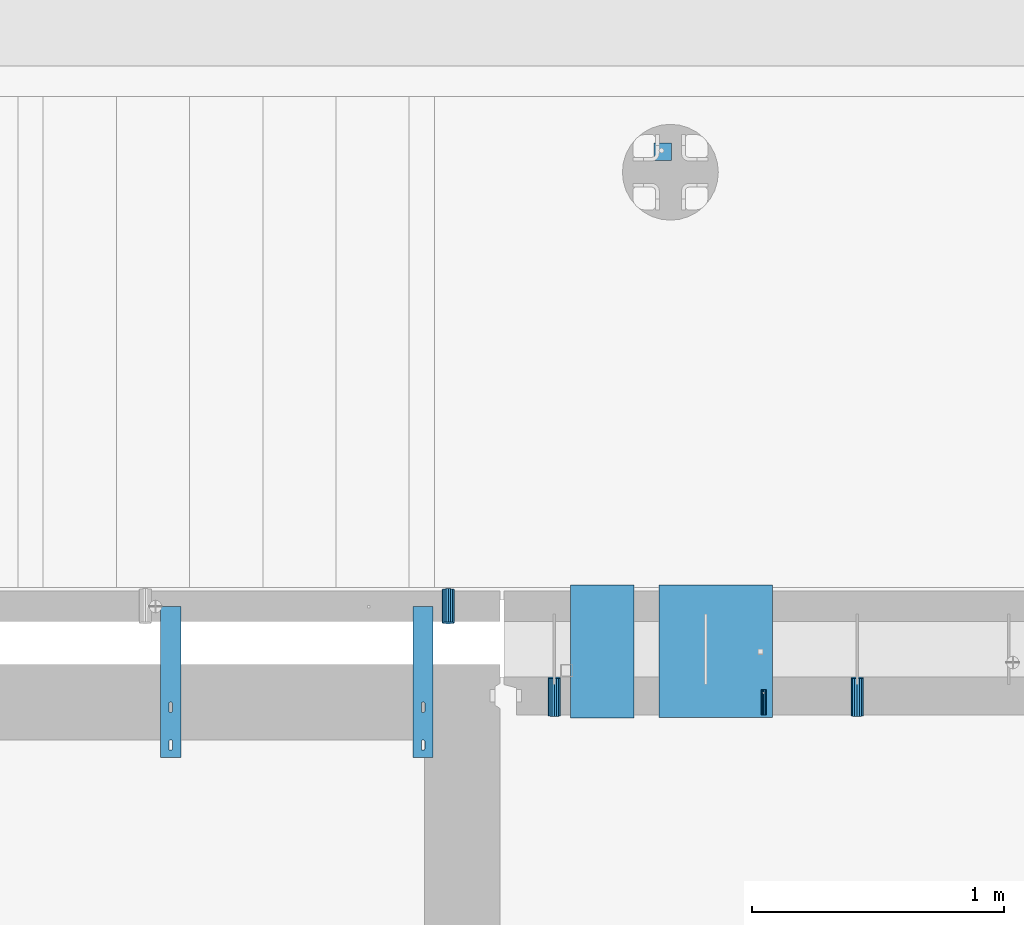
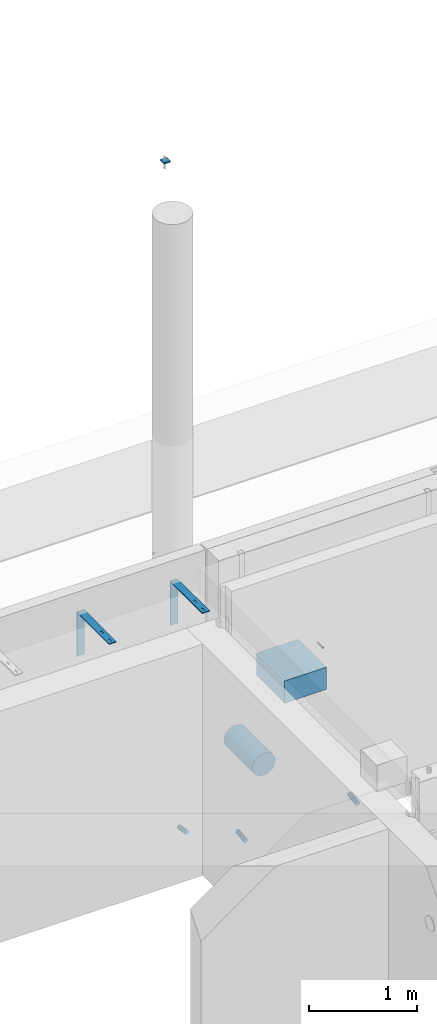
# One storey, part 102 of 264: 9 beams, 12 elements without a shape of their own.
"""IFC2X3 building model written with IfcOpenShell, lengths in millimetres."""

from ifc_helpers import new_model, si_unit, frame, origin_with_axes, place, context, subcontext, project, spatial, faceted_brep, material, type_object, element, aggregate, save


model = new_model("IFC2X3")

# Units and contexts
model_context = context("Model", 3, precision=1e-05, world=origin_with_axes())
body_context = subcontext(model_context, "Body", "Model", "MODEL_VIEW")
ifc_project = project(units=[si_unit("LENGTHUNIT", "METRE", prefix="MILLI"), si_unit("AREAUNIT", "SQUARE_METRE"), si_unit("VOLUMEUNIT", "CUBIC_METRE"), si_unit("MASSUNIT", "GRAM", prefix="KILO"), si_unit("TIMEUNIT", "SECOND"), si_unit("PLANEANGLEUNIT", "RADIAN"), si_unit("SOLIDANGLEUNIT", "STERADIAN"), si_unit("THERMODYNAMICTEMPERATUREUNIT", "DEGREE_CELSIUS"), si_unit("LUMINOUSINTENSITYUNIT", "LUMEN")], contexts=[model_context])

# Site, building, storey
site_placement = place(None, origin_with_axes())
site = spatial("IfcSite", under=ifc_project, at=site_placement, CompositionType="ELEMENT")
building_placement = place(site_placement, origin_with_axes())
building = spatial("IfcBuilding", under=site, at=building_placement, CompositionType="ELEMENT")
storey_placement = place(building_placement, origin_with_axes())
storey = spatial("IfcBuildingStorey", under=building, at=storey_placement, Name="K", CompositionType="ELEMENT", Elevation=0.0)

# Assemblies, beam
assembly_1_placement = place(storey_placement, origin_with_axes())
assembly_1 = element("IfcElementAssembly", 1, at=assembly_1_placement, inside=storey, AssemblyPlace="NOTDEFINED", PredefinedType="REINFORCEMENT_UNIT")
assembly_2_placement = place(assembly_1_placement, origin_with_axes())
assembly_2 = element("IfcElementAssembly", 2, at=assembly_2_placement, Name="Steel Assembly", AssemblyPlace="NOTDEFINED", PredefinedType="RIGID_FRAME")
ifc_material_1 = material(Name="STEEL/Steel_Undefined")
beam_type_1 = type_object("IfcBeamType", PredefinedType="NOTDEFINED")
beam_1_placement = place(assembly_2_placement, frame((14745.0036427287, 20429.9997001067, 80490.0), z_axis=(-1.0, 3.00000001838171e-08, 0.0), x_axis=(0.0, 1.0, 0.0)))
beam_1 = element("IfcBeam", 3, at=beam_1_placement, type_object=beam_type_1, material=ifc_material_1, Name="M16", context=body_context, shape_type="Brep", body=[
    faceted_brep([(0.0, -8.49999999999272, -1.45519152283669e-11), (0.0, -7.36121593215648, 4.24999999998545), (100.000000000262, -7.36121593215648, 4.24999999998545), (100.000000000262, -8.49999999999272, -1.45519152283669e-11), (0.0, -4.24999999998545, 7.36121593216376), (100.000000000262, -4.24999999998545, 7.36121593216376), (0.0, 1.45519152283669e-11, 8.49999999998545), (100.000000000262, 1.45519152283669e-11, 8.49999999998545), (0.0, 4.25000000001455, 7.36121593216376), (100.000000000262, 4.25000000001455, 7.36121593216376), (0.0, 7.36121593217104, 4.24999999998545), (100.000000000262, 7.36121593217104, 4.24999999998545), (0.0, 8.50000000000728, 0.0), (100.000000000262, 8.50000000000728, 0.0), (0.0, 7.36121593217104, -4.25000000001455), (100.000000000262, 7.36121593217104, -4.25000000001455), (0.0, 4.25000000000728, -7.36121593219286), (100.000000000262, 4.25000000000728, -7.36121593219286), (0.0, 7.27595761418343e-12, -8.5), (100.000000000262, 7.27595761418343e-12, -8.5), (0.0, -4.24999999999272, -7.36121593217831), (100.000000000262, -4.24999999999272, -7.36121593217831), (0.0, -7.36121593215648, -4.25), (100.000000000262, -7.36121593215648, -4.25), (0.0, -10.4999999999927, -1.45519152283669e-11), (0.0, -9.09326673972828, -5.25000000001455), (100.000000000262, -9.09326673972828, -5.25000000001455), (100.000000000262, -10.4999999999927, -1.45519152283669e-11), (0.0, -5.24999999998545, -9.09326673974283), (100.000000000262, -5.24999999998545, -9.09326673974283), (0.0, 7.27595761418343e-12, -10.5), (100.000000000262, 7.27595761418343e-12, -10.5), (0.0, 5.25000000001455, -9.09326673975738), (100.000000000262, 5.25000000001455, -9.09326673975738), (0.0, 9.09326673975011, -5.25000000001455), (100.000000000262, 9.09326673975011, -5.25000000001455), (0.0, 10.5000000000073, -1.45519152283669e-11), (100.000000000262, 10.5000000000073, -1.45519152283669e-11), (0.0, 9.09326673975011, 5.25), (100.000000000262, 9.09326673975011, 5.25), (0.0, 5.25000000000728, 9.09326673972828), (100.000000000262, 5.25000000000728, 9.09326673972828), (0.0, 1.45519152283669e-11, 10.4999999999854), (100.000000000262, 1.45519152283669e-11, 10.4999999999854), (0.0, -5.24999999999272, 9.09326673972828), (100.000000000262, -5.24999999999272, 9.09326673972828), (0.0, -9.09326673972828, 5.24999999998545), (100.000000000262, -9.09326673972828, 5.24999999998545)], [[[0, 1, 2, 3]], [[1, 4, 5, 2]], [[4, 6, 7, 5]], [[6, 8, 9, 7]], [[8, 10, 11, 9]], [[10, 12, 13, 11]], [[12, 14, 15, 13]], [[14, 16, 17, 15]], [[16, 18, 19, 17]], [[18, 20, 21, 19]], [[20, 22, 23, 21]], [[22, 0, 3, 23]], [[24, 25, 26, 27]], [[25, 28, 29, 26]], [[28, 30, 31, 29]], [[30, 32, 33, 31]], [[32, 34, 35, 33]], [[34, 36, 37, 35]], [[36, 38, 39, 37]], [[38, 40, 41, 39]], [[40, 42, 43, 41]], [[42, 44, 45, 43]], [[44, 46, 47, 45]], [[46, 24, 27, 47]], [[29, 31, 33, 35, 37, 39, 41, 43, 45, 47, 27, 26], [5, 7, 9, 11, 13, 15, 17, 19, 21, 23, 3, 2]], [[46, 44, 42, 40, 38, 36, 34, 32, 30, 28, 25, 24], [22, 20, 18, 16, 14, 12, 10, 8, 6, 4, 1, 0]]]),
])
aggregate(assembly_2, [beam_1])

assembly_3_placement = place(storey_placement, origin_with_axes())
assembly_3 = element("IfcElementAssembly", 4, at=assembly_3_placement, inside=storey, AssemblyPlace="NOTDEFINED", PredefinedType="REINFORCEMENT_UNIT")
assembly_4_placement = place(assembly_3_placement, origin_with_axes())
assembly_4 = element("IfcElementAssembly", 5, at=assembly_4_placement, Name="Steel Assembly", AssemblyPlace="NOTDEFINED", PredefinedType="RIGID_FRAME")
aggregate(assembly_3, [assembly_4])
beam_type_2 = type_object("IfcBeamType", PredefinedType="NOTDEFINED")
beam_2_placement = place(assembly_4_placement, frame((14345.0, 22625.9999913613, 84792.5), z_axis=(-1.0, 3.00000001838171e-08, 0.0), x_axis=(0.0, 1.0, 0.0)))
beam_2 = element("IfcBeam", 6, at=beam_2_placement, type_object=beam_type_2, material=ifc_material_1, Name="BEAM", context=body_context, shape_type="Brep", body=[
    faceted_brep([(0.0, 7.5, -35.0), (0.0, 7.5, 35.0), (70.0, 7.5, 35.0), (70.0, 7.5, -35.0), (0.0, -7.5, 35.0), (70.0, -7.5, 35.0), (0.0, -7.5, -35.0), (70.0, -7.5, -35.0)], [[[0, 1, 2, 3]], [[1, 4, 5, 2]], [[4, 6, 7, 5]], [[6, 0, 3, 7]], [[5, 7, 3, 2]], [[6, 4, 1, 0]]]),
])
aggregate(assembly_4, [beam_2])

assembly_5_placement = place(storey_placement, origin_with_axes())
assembly_5 = element("IfcElementAssembly", 7, at=assembly_5_placement, inside=storey, AssemblyPlace="NOTDEFINED", PredefinedType="REINFORCEMENT_UNIT")
assembly_6_placement = place(assembly_5_placement, origin_with_axes())
assembly_6 = element("IfcElementAssembly", 8, at=assembly_6_placement, Name="Steel Assembly", AssemblyPlace="NOTDEFINED", PredefinedType="NOTDEFINED")
ifc_material_2 = material()
beam_type_3 = type_object("IfcBeamType", Name="D50", PredefinedType="NOTDEFINED")
beam_3_placement = place(assembly_6_placement, frame((13494.9999997536, 20794.388890547, 78614.7172983598), z_axis=(-1.0, 3.00000001838171e-08, 0.0), x_axis=(-5.60000020538061e-08, 0.988691934499859, -0.14996085707585)))
beam_3 = element("IfcBeam", 9, at=beam_3_placement, type_object=beam_type_3, material=ifc_material_2, ObjectType="D50", context=body_context, shape_type="Brep", body=[
    faceted_brep([(0.0, -25.0, 0.0), (-3.63797880709171e-12, -23.0969883127837, -9.56708580912891), (133.368135763521, -23.0969883127691, -9.56708580912709), (133.368135766923, -24.9999999999854, 1.81898940354586e-12), (-3.63797880709171e-12, -17.6776695296576, -17.6776695296649), (133.36813576064, -17.6776695296576, -17.677669529663), (-1.09139364212751e-11, -9.56708580913255, -23.0969883127837), (133.368135758712, -9.567085809118, -23.0969883127818), (-1.09139364212751e-11, 0.0, -25.0), (133.368135758034, 0.0, -25.0), (-1.09139364212751e-11, 9.56708580913255, -23.0969883127837), (133.36813575871, 9.56708580913255, -23.0969883127837), (-3.63797880709171e-12, 17.6776695296576, -17.6776695296649), (133.36813576064, 17.6776695296721, -17.677669529663), (-3.63797880709171e-12, 23.0969883127837, -9.56708580912891), (133.36813576352, 23.0969883127982, -9.56708580912709), (0.0, 25.0, 0.0), (133.368135766925, 25.0000000000146, -1.81898940354586e-12), (7.27595761418343e-12, 23.0969883127837, 9.56708580912891), (133.368135770323, 23.0969883127837, 9.56708580912709), (7.27595761418343e-12, 17.6776695296576, 17.6776695296649), (133.368135773204, 17.6776695296721, 17.6776695296649), (1.45519152283669e-11, 9.56708580913255, 23.0969883127837), (133.368135775132, 9.5670858091471, 23.0969883127837), (1.09139364212751e-11, 0.0, 25.0), (133.368135775807, 1.45519152283669e-11, 25.0), (1.45519152283669e-11, -9.56708580913255, 23.0969883127837), (133.368135775134, -9.56708580910345, 23.0969883127837), (7.27595761418343e-12, -17.6776695296576, 17.6776695296649), (133.368135773204, -17.6776695296721, 17.6776695296649), (7.27595761418343e-12, -23.0969883127837, 9.56708580912891), (133.368135770321, -23.0969883127691, 9.56708580912709)], [[[0, 1, 2, 3]], [[1, 4, 5, 2]], [[4, 6, 7, 5]], [[6, 8, 9, 7]], [[8, 10, 11, 9]], [[10, 12, 13, 11]], [[12, 14, 15, 13]], [[14, 16, 17, 15]], [[16, 18, 19, 17]], [[18, 20, 21, 19]], [[20, 22, 23, 21]], [[22, 24, 25, 23]], [[24, 26, 27, 25]], [[26, 28, 29, 27]], [[28, 30, 31, 29]], [[30, 0, 3, 31]], [[5, 7, 9, 11, 13, 15, 17, 19, 21, 23, 25, 27, 29, 31, 3, 2]], [[30, 28, 26, 24, 22, 20, 18, 16, 14, 12, 10, 8, 6, 4, 1, 0]]]),
])
aggregate(assembly_6, [beam_3])

# Assembly, beam
assembly_7_placement = place(assembly_1_placement, origin_with_axes())
assembly_7 = element("IfcElementAssembly", 10, at=assembly_7_placement, Name="Steel Assembly", AssemblyPlace="NOTDEFINED", PredefinedType="NOTDEFINED")
beam_4_placement = place(assembly_7_placement, frame((15115.00337189, 20576.6953842789, 78614.7806975163), z_axis=(-1.0, 3.00000001838171e-08, 0.0), x_axis=(-2.85000000728153e-07, -0.991227900700062, -0.132163719960004)))
beam_4 = element("IfcBeam", 11, at=beam_4_placement, type_object=beam_type_3, material=ifc_material_2, ObjectType="D50", context=body_context, shape_type="Brep", body=[
    faceted_brep([(0.0, -25.0, 0.0), (-3.63797880709171e-12, -23.0969883127837, -9.56708580912891), (151.327459502041, -23.0969883127837, -9.56708580913255), (151.327459506574, -25.0, 0.0), (-3.63797880709171e-12, -17.6776695296576, -17.6776695296649), (151.327459498199, -17.6776695296721, -17.6776695296649), (-1.09139364212751e-11, -9.56708580913255, -23.0969883127837), (151.327459495631, -9.56708580913255, -23.0969883127837), (-1.09139364212751e-11, 0.0, -25.0), (151.327459494732, 1.45519152283669e-11, -25.0), (-1.09139364212751e-11, 9.56708580913255, -23.0969883127837), (151.327459495635, 9.56708580913255, -23.0969883127873), (-3.63797880709171e-12, 17.6776695296576, -17.6776695296649), (151.327459498196, 17.6776695296721, -17.6776695296649), (-3.63797880709171e-12, 23.0969883127837, -9.56708580912891), (151.327459502041, 23.0969883127982, -9.56708580912527), (0.0, 25.0, 0.0), (151.32745950657, 25.0000000000146, 0.0), (7.27595761418343e-12, 23.0969883127837, 9.56708580912891), (151.327459511107, 23.0969883127837, 9.56708580912891), (7.27595761418343e-12, 17.6776695296576, 17.6776695296649), (151.327459514949, 17.6776695296721, 17.6776695296649), (1.45519152283669e-11, 9.56708580913255, 23.0969883127837), (151.327459517513, 9.5670858091471, 23.09698831278), (1.09139364212751e-11, 0.0, 25.0), (151.327459518412, 0.0, 25.0000000000036), (1.45519152283669e-11, -9.56708580913255, 23.0969883127837), (151.32745951751, -9.567085809118, 23.0969883127837), (7.27595761418343e-12, -17.6776695296576, 17.6776695296649), (151.327459514949, -17.6776695296576, 17.6776695296649), (7.27595761418343e-12, -23.0969883127837, 9.56708580912891), (151.327459511107, -23.0969883127837, 9.56708580912527)], [[[0, 1, 2, 3]], [[1, 4, 5, 2]], [[4, 6, 7, 5]], [[6, 8, 9, 7]], [[8, 10, 11, 9]], [[10, 12, 13, 11]], [[12, 14, 15, 13]], [[14, 16, 17, 15]], [[16, 18, 19, 17]], [[18, 20, 21, 19]], [[20, 22, 23, 21]], [[22, 24, 25, 23]], [[24, 26, 27, 25]], [[26, 28, 29, 27]], [[28, 30, 31, 29]], [[30, 0, 3, 31]], [[5, 7, 9, 11, 13, 15, 17, 19, 21, 23, 25, 27, 29, 31, 3, 2]], [[30, 28, 26, 24, 22, 20, 18, 16, 14, 12, 10, 8, 6, 4, 1, 0]]]),
])
aggregate(assembly_7, [beam_4])

# Assembly
assembly_8_placement = place(assembly_1_placement, origin_with_axes())
assembly_8 = element("IfcElementAssembly", 12, at=assembly_8_placement, Name="Steel Assembly", AssemblyPlace="NOTDEFINED", PredefinedType="NOTDEFINED")

aggregate(assembly_1, [assembly_2, assembly_7, assembly_8])

# Beam
beam_5_placement = place(assembly_8_placement, frame((13915.0033718897, 20576.6957298796, 78614.7806975163), z_axis=(-1.0, 3.00000001838171e-08, 0.0), x_axis=(-2.85000000728153e-07, -0.991227900700062, -0.132163719960004)))
beam_5 = element("IfcBeam", 13, at=beam_5_placement, type_object=beam_type_3, material=ifc_material_2, ObjectType="D50", context=body_context, shape_type="Brep", body=[
    faceted_brep([(0.0, -25.0, 0.0), (-3.63797880709171e-12, -23.0969883127837, -9.56708580912891), (151.327459502041, -23.0969883127837, -9.56708580913255), (151.327459506574, -25.0, 0.0), (-3.63797880709171e-12, -17.6776695296576, -17.6776695296649), (151.327459498199, -17.6776695296721, -17.6776695296649), (-1.09139364212751e-11, -9.56708580913255, -23.0969883127837), (151.327459495631, -9.56708580913255, -23.0969883127837), (-1.09139364212751e-11, 0.0, -25.0), (151.327459494732, 1.45519152283669e-11, -25.0), (-1.09139364212751e-11, 9.56708580913255, -23.0969883127837), (151.327459495635, 9.56708580913255, -23.0969883127873), (-3.63797880709171e-12, 17.6776695296576, -17.6776695296649), (151.327459498196, 17.6776695296721, -17.6776695296649), (-3.63797880709171e-12, 23.0969883127837, -9.56708580912891), (151.327459502041, 23.0969883127982, -9.56708580912527), (0.0, 25.0, 0.0), (151.32745950657, 25.0000000000146, 0.0), (7.27595761418343e-12, 23.0969883127837, 9.56708580912891), (151.327459511107, 23.0969883127837, 9.56708580912891), (7.27595761418343e-12, 17.6776695296576, 17.6776695296649), (151.327459514949, 17.6776695296721, 17.6776695296649), (1.45519152283669e-11, 9.56708580913255, 23.0969883127837), (151.327459517513, 9.5670858091471, 23.09698831278), (1.09139364212751e-11, 0.0, 25.0), (151.327459518412, 0.0, 25.0000000000036), (1.45519152283669e-11, -9.56708580913255, 23.0969883127837), (151.32745951751, -9.567085809118, 23.0969883127837), (7.27595761418343e-12, -17.6776695296576, 17.6776695296649), (151.327459514949, -17.6776695296576, 17.6776695296649), (7.27595761418343e-12, -23.0969883127837, 9.56708580912891), (151.327459511107, -23.0969883127837, 9.56708580912527)], [[[0, 1, 2, 3]], [[1, 4, 5, 2]], [[4, 6, 7, 5]], [[6, 8, 9, 7]], [[8, 10, 11, 9]], [[10, 12, 13, 11]], [[12, 14, 15, 13]], [[14, 16, 17, 15]], [[16, 18, 19, 17]], [[18, 20, 21, 19]], [[20, 22, 23, 21]], [[22, 24, 25, 23]], [[24, 26, 27, 25]], [[26, 28, 29, 27]], [[28, 30, 31, 29]], [[30, 0, 3, 31]], [[5, 7, 9, 11, 13, 15, 17, 19, 21, 23, 25, 27, 29, 31, 3, 2]], [[30, 28, 26, 24, 22, 20, 18, 16, 14, 12, 10, 8, 6, 4, 1, 0]]]),
])

aggregate(assembly_8, [beam_5])

# Assembly, beam
assembly_9_placement = place(assembly_5_placement, origin_with_axes())
assembly_9 = element("IfcElementAssembly", 14, at=assembly_9_placement, Name="Steel Assembly", AssemblyPlace="NOTDEFINED", PredefinedType="RIGID_FRAME")
ifc_material_3 = material(Name="STEEL/1.4301")
beam_type_4 = type_object("IfcBeamType", PredefinedType="NOTDEFINED")
beam_6_placement = place(assembly_9_placement, frame((13355.0, 20560.0, 81220.0), z_axis=(0.0, -1.0, 0.0), x_axis=(1.0, 0.0, 0.0)))
beam_6 = element("IfcBeam", 15, at=beam_6_placement, type_object=beam_type_4, material=ifc_material_3, Name="RST", context=body_context, shape_type="Brep", body=[
    faceted_brep([(46.9999999999854, 250.0, 84.9999999999964), (46.9999999999854, 242.0, 84.9999999999964), (46.9999999999854, 242.0, 114.999999999996), (46.9999999999854, 250.0, 114.999999999996), (46.7552825814619, 242.0, 116.545084971873), (46.7552825814619, 250.0, 116.545084971873), (46.04508497186, 242.0, 117.93892626146), (46.04508497186, 250.0, 117.93892626146), (44.9389262614477, 242.0, 119.045084971873), (44.9389262614477, 250.0, 119.045084971873), (43.54508497186, 242.0, 119.755282581471), (43.54508497186, 250.0, 119.755282581471), (41.9999999999854, 242.0, 119.999999999996), (41.9999999999854, 250.0, 119.999999999996), (37.9999999999854, 242.0, 119.999999999996), (37.9999999999854, 250.0, 119.999999999996), (36.4549150281109, 242.0, 119.755282581471), (36.4549150281109, 250.0, 119.755282581471), (35.0610737385232, 242.0, 119.045084971873), (35.0610737385232, 250.0, 119.045084971873), (33.9549150281109, 242.0, 117.93892626146), (33.9549150281109, 250.0, 117.93892626146), (33.244717418509, 242.0, 116.545084971873), (33.244717418509, 250.0, 116.545084971873), (32.9999999999854, 242.0, 114.999999999996), (32.9999999999854, 250.0, 114.999999999996), (32.9999999999854, 242.0, 84.9999999999964), (32.9999999999854, 250.0, 84.9999999999964), (33.244717418509, 242.0, 83.4549150281237), (33.244717418509, 250.0, 83.4549150281237), (33.9549150281109, 242.0, 82.0610737385359), (33.9549150281109, 250.0, 82.0610737385359), (35.0610737385232, 242.0, 80.9549150281237), (35.0610737385232, 250.0, 80.9549150281237), (36.4549150281109, 242.0, 80.2447174185218), (36.4549150281109, 250.0, 80.2447174185218), (37.9999999999854, 242.0, 79.9999999999964), (37.9999999999854, 250.0, 79.9999999999964), (41.9999999999854, 242.0, 79.9999999999964), (41.9999999999854, 250.0, 79.9999999999964), (43.54508497186, 242.0, 80.2447174185218), (43.54508497186, 250.0, 80.2447174185218), (44.9389262614477, 242.0, 80.9549150281237), (44.9389262614477, 250.0, 80.9549150281237), (46.04508497186, 242.0, 82.0610737385359), (46.04508497186, 250.0, 82.0610737385359), (46.7552825814619, 242.0, 83.4549150281237), (46.7552825814619, 250.0, 83.4549150281237), (0.0, -250.0, -292.0), (0.0, -250.0, -300.0), (80.0, -250.0, -300.0), (80.0, -250.0, -292.0), (0.0, 242.0, -292.0), (80.0, 242.0, -292.0), (0.0, 250.0, 300.0), (0.0, 242.0, 300.0), (80.0, 242.0, 300.0), (80.0, 250.0, 300.0), (0.0, 250.0, -300.0), (80.0, 250.0, -300.0), (46.9999999999854, 250.0, 264.999999999996), (46.7552825814619, 250.0, 266.545084971873), (46.04508497186, 250.0, 267.93892626146), (44.9389262614477, 250.0, 269.045084971873), (43.54508497186, 250.0, 269.755282581471), (41.9999999999854, 250.0, 269.999999999996), (37.9999999999854, 250.0, 269.999999999996), (36.4549150281109, 250.0, 269.755282581471), (35.0610737385232, 250.0, 269.045084971873), (33.9549150281109, 250.0, 267.93892626146), (33.244717418509, 250.0, 266.545084971873), (32.9999999999854, 250.0, 264.999999999996), (32.9999999999854, 250.0, 234.999999999996), (33.244717418509, 250.0, 233.454915028124), (33.9549150281109, 250.0, 232.061073738536), (35.0610737385232, 250.0, 230.954915028124), (36.4549150281109, 250.0, 230.244717418522), (37.9999999999854, 250.0, 229.999999999996), (41.9999999999854, 250.0, 229.999999999996), (43.54508497186, 250.0, 230.244717418522), (44.9389262614477, 250.0, 230.954915028124), (46.04508497186, 250.0, 232.061073738536), (46.7552825814619, 250.0, 233.454915028124), (46.9999999999854, 250.0, 234.999999999996), (44.9389262614477, 242.0, 230.954915028124), (46.04508497186, 242.0, 232.061073738536), (43.54508497186, 242.0, 230.244717418522), (41.9999999999854, 242.0, 229.999999999996), (37.9999999999854, 242.0, 229.999999999996), (36.4549150281109, 242.0, 230.244717418522), (35.0610737385232, 242.0, 230.954915028124), (33.9549150281109, 242.0, 232.061073738536), (33.244717418509, 242.0, 233.454915028124), (32.9999999999854, 242.0, 234.999999999996), (32.9999999999854, 242.0, 264.999999999996), (33.244717418509, 242.0, 266.545084971873), (33.9549150281109, 242.0, 267.93892626146), (35.0610737385232, 242.0, 269.045084971873), (36.4549150281109, 242.0, 269.755282581471), (37.9999999999854, 242.0, 269.999999999996), (41.9999999999854, 242.0, 269.999999999996), (43.54508497186, 242.0, 269.755282581471), (44.9389262614477, 242.0, 269.045084971873), (46.04508497186, 242.0, 267.93892626146), (46.7552825814619, 242.0, 266.545084971873), (46.9999999999854, 242.0, 264.999999999996), (46.9999999999854, 242.0, 234.999999999996), (46.7552825814619, 242.0, 233.454915028124)], [[[0, 1, 2, 3]], [[3, 2, 4, 5]], [[5, 4, 6, 7]], [[7, 6, 8, 9]], [[9, 8, 10, 11]], [[11, 10, 12, 13]], [[13, 12, 14, 15]], [[15, 14, 16, 17]], [[17, 16, 18, 19]], [[19, 18, 20, 21]], [[21, 20, 22, 23]], [[23, 22, 24, 25]], [[25, 24, 26, 27]], [[27, 26, 28, 29]], [[29, 28, 30, 31]], [[31, 30, 32, 33]], [[33, 32, 34, 35]], [[35, 34, 36, 37]], [[37, 36, 38, 39]], [[39, 38, 40, 41]], [[41, 40, 42, 43]], [[43, 42, 44, 45]], [[45, 44, 46, 47]], [[47, 46, 1, 0]], [[48, 49, 50, 51]], [[52, 48, 51, 53]], [[54, 55, 56, 57]], [[49, 48, 52, 55, 54, 58]], [[49, 58, 59, 50]], [[56, 53, 51, 50, 59, 57]], [[58, 54, 57, 59], [3, 5, 7, 9, 11, 13, 15, 17, 19, 21, 23, 25, 27, 29, 31, 33, 35, 37, 39, 41, 43, 45, 47, 0], [60, 61, 62, 63, 64, 65, 66, 67, 68, 69, 70, 71, 72, 73, 74, 75, 76, 77, 78, 79, 80, 81, 82, 83]], [[80, 84, 85, 81]], [[79, 86, 84, 80]], [[78, 87, 86, 79]], [[77, 88, 87, 78]], [[76, 89, 88, 77]], [[75, 90, 89, 76]], [[74, 91, 90, 75]], [[73, 92, 91, 74]], [[72, 93, 92, 73]], [[71, 94, 93, 72]], [[70, 95, 94, 71]], [[69, 96, 95, 70]], [[68, 97, 96, 69]], [[67, 98, 97, 68]], [[66, 99, 98, 67]], [[65, 100, 99, 66]], [[64, 101, 100, 65]], [[63, 102, 101, 64]], [[62, 103, 102, 63]], [[61, 104, 103, 62]], [[60, 105, 104, 61]], [[83, 106, 105, 60]], [[82, 107, 106, 83]], [[81, 85, 107, 82]], [[55, 52, 53, 56], [42, 40, 38, 36, 34, 32, 30, 28, 26, 24, 22, 20, 18, 16, 14, 12, 10, 8, 6, 4, 2, 1, 46, 44], [84, 86, 87, 88, 89, 90, 91, 92, 93, 94, 95, 96, 97, 98, 99, 100, 101, 102, 103, 104, 105, 106, 107, 85]]]),
])
aggregate(assembly_9, [beam_6])

# Assembly
assembly_10_placement = place(assembly_5_placement, origin_with_axes())
assembly_10 = element("IfcElementAssembly", 16, at=assembly_10_placement, Name="Steel Assembly", AssemblyPlace="NOTDEFINED", PredefinedType="RIGID_FRAME")

aggregate(assembly_5, [assembly_6, assembly_9, assembly_10])

# Beam
beam_7_placement = place(assembly_10_placement, frame((12355.0, 20560.0, 81220.0), z_axis=(0.0, -1.0, 0.0), x_axis=(1.0, 0.0, 0.0)))
beam_7 = element("IfcBeam", 17, at=beam_7_placement, type_object=beam_type_4, material=ifc_material_3, Name="RST", context=body_context, shape_type="Brep", body=[
    faceted_brep([(46.9999999999854, 250.0, 84.9999999999964), (46.9999999999854, 242.0, 84.9999999999964), (46.9999999999854, 242.0, 114.999999999996), (46.9999999999854, 250.0, 114.999999999996), (46.7552825814619, 242.0, 116.545084971873), (46.7552825814619, 250.0, 116.545084971873), (46.04508497186, 242.0, 117.93892626146), (46.04508497186, 250.0, 117.93892626146), (44.9389262614477, 242.0, 119.045084971873), (44.9389262614477, 250.0, 119.045084971873), (43.54508497186, 242.0, 119.755282581471), (43.54508497186, 250.0, 119.755282581471), (41.9999999999854, 242.0, 119.999999999996), (41.9999999999854, 250.0, 119.999999999996), (37.9999999999854, 242.0, 119.999999999996), (37.9999999999854, 250.0, 119.999999999996), (36.4549150281109, 242.0, 119.755282581471), (36.4549150281109, 250.0, 119.755282581471), (35.0610737385232, 242.0, 119.045084971873), (35.0610737385232, 250.0, 119.045084971873), (33.9549150281109, 242.0, 117.93892626146), (33.9549150281109, 250.0, 117.93892626146), (33.244717418509, 242.0, 116.545084971873), (33.244717418509, 250.0, 116.545084971873), (32.9999999999854, 242.0, 114.999999999996), (32.9999999999854, 250.0, 114.999999999996), (32.9999999999854, 242.0, 84.9999999999964), (32.9999999999854, 250.0, 84.9999999999964), (33.244717418509, 242.0, 83.4549150281237), (33.244717418509, 250.0, 83.4549150281237), (33.9549150281109, 242.0, 82.0610737385359), (33.9549150281109, 250.0, 82.0610737385359), (35.0610737385232, 242.0, 80.9549150281237), (35.0610737385232, 250.0, 80.9549150281237), (36.4549150281109, 242.0, 80.2447174185218), (36.4549150281109, 250.0, 80.2447174185218), (37.9999999999854, 242.0, 79.9999999999964), (37.9999999999854, 250.0, 79.9999999999964), (41.9999999999854, 242.0, 79.9999999999964), (41.9999999999854, 250.0, 79.9999999999964), (43.54508497186, 242.0, 80.2447174185218), (43.54508497186, 250.0, 80.2447174185218), (44.9389262614477, 242.0, 80.9549150281237), (44.9389262614477, 250.0, 80.9549150281237), (46.04508497186, 242.0, 82.0610737385359), (46.04508497186, 250.0, 82.0610737385359), (46.7552825814619, 242.0, 83.4549150281237), (46.7552825814619, 250.0, 83.4549150281237), (0.0, -250.0, -292.0), (0.0, -250.0, -300.0), (80.0, -250.0, -300.0), (80.0, -250.0, -292.0), (0.0, 242.0, -292.0), (80.0, 242.0, -292.0), (0.0, 250.0, 300.0), (0.0, 242.0, 300.0), (80.0, 242.0, 300.0), (80.0, 250.0, 300.0), (0.0, 250.0, -300.0), (80.0, 250.0, -300.0), (46.9999999999854, 250.0, 264.999999999996), (46.7552825814619, 250.0, 266.545084971873), (46.04508497186, 250.0, 267.93892626146), (44.9389262614477, 250.0, 269.045084971873), (43.54508497186, 250.0, 269.755282581471), (41.9999999999854, 250.0, 269.999999999996), (37.9999999999854, 250.0, 269.999999999996), (36.4549150281109, 250.0, 269.755282581471), (35.0610737385232, 250.0, 269.045084971873), (33.9549150281109, 250.0, 267.93892626146), (33.244717418509, 250.0, 266.545084971873), (32.9999999999854, 250.0, 264.999999999996), (32.9999999999854, 250.0, 234.999999999996), (33.244717418509, 250.0, 233.454915028124), (33.9549150281109, 250.0, 232.061073738536), (35.0610737385232, 250.0, 230.954915028124), (36.4549150281109, 250.0, 230.244717418522), (37.9999999999854, 250.0, 229.999999999996), (41.9999999999854, 250.0, 229.999999999996), (43.54508497186, 250.0, 230.244717418522), (44.9389262614477, 250.0, 230.954915028124), (46.04508497186, 250.0, 232.061073738536), (46.7552825814619, 250.0, 233.454915028124), (46.9999999999854, 250.0, 234.999999999996), (44.9389262614477, 242.0, 230.954915028124), (46.04508497186, 242.0, 232.061073738536), (43.54508497186, 242.0, 230.244717418522), (41.9999999999854, 242.0, 229.999999999996), (37.9999999999854, 242.0, 229.999999999996), (36.4549150281109, 242.0, 230.244717418522), (35.0610737385232, 242.0, 230.954915028124), (33.9549150281109, 242.0, 232.061073738536), (33.244717418509, 242.0, 233.454915028124), (32.9999999999854, 242.0, 234.999999999996), (32.9999999999854, 242.0, 264.999999999996), (33.244717418509, 242.0, 266.545084971873), (33.9549150281109, 242.0, 267.93892626146), (35.0610737385232, 242.0, 269.045084971873), (36.4549150281109, 242.0, 269.755282581471), (37.9999999999854, 242.0, 269.999999999996), (41.9999999999854, 242.0, 269.999999999996), (43.54508497186, 242.0, 269.755282581471), (44.9389262614477, 242.0, 269.045084971873), (46.04508497186, 242.0, 267.93892626146), (46.7552825814619, 242.0, 266.545084971873), (46.9999999999854, 242.0, 264.999999999996), (46.9999999999854, 242.0, 234.999999999996), (46.7552825814619, 242.0, 233.454915028124)], [[[0, 1, 2, 3]], [[3, 2, 4, 5]], [[5, 4, 6, 7]], [[7, 6, 8, 9]], [[9, 8, 10, 11]], [[11, 10, 12, 13]], [[13, 12, 14, 15]], [[15, 14, 16, 17]], [[17, 16, 18, 19]], [[19, 18, 20, 21]], [[21, 20, 22, 23]], [[23, 22, 24, 25]], [[25, 24, 26, 27]], [[27, 26, 28, 29]], [[29, 28, 30, 31]], [[31, 30, 32, 33]], [[33, 32, 34, 35]], [[35, 34, 36, 37]], [[37, 36, 38, 39]], [[39, 38, 40, 41]], [[41, 40, 42, 43]], [[43, 42, 44, 45]], [[45, 44, 46, 47]], [[47, 46, 1, 0]], [[48, 49, 50, 51]], [[52, 48, 51, 53]], [[54, 55, 56, 57]], [[49, 48, 52, 55, 54, 58]], [[49, 58, 59, 50]], [[56, 53, 51, 50, 59, 57]], [[58, 54, 57, 59], [3, 5, 7, 9, 11, 13, 15, 17, 19, 21, 23, 25, 27, 29, 31, 33, 35, 37, 39, 41, 43, 45, 47, 0], [60, 61, 62, 63, 64, 65, 66, 67, 68, 69, 70, 71, 72, 73, 74, 75, 76, 77, 78, 79, 80, 81, 82, 83]], [[80, 84, 85, 81]], [[79, 86, 84, 80]], [[78, 87, 86, 79]], [[77, 88, 87, 78]], [[76, 89, 88, 77]], [[75, 90, 89, 76]], [[74, 91, 90, 75]], [[73, 92, 91, 74]], [[72, 93, 92, 73]], [[71, 94, 93, 72]], [[70, 95, 94, 71]], [[69, 96, 95, 70]], [[68, 97, 96, 69]], [[67, 98, 97, 68]], [[66, 99, 98, 67]], [[65, 100, 99, 66]], [[64, 101, 100, 65]], [[63, 102, 101, 64]], [[62, 103, 102, 63]], [[61, 104, 103, 62]], [[60, 105, 104, 61]], [[83, 106, 105, 60]], [[82, 107, 106, 83]], [[81, 85, 107, 82]], [[55, 52, 53, 56], [42, 40, 38, 36, 34, 32, 30, 28, 26, 24, 22, 20, 18, 16, 14, 12, 10, 8, 6, 4, 2, 1, 46, 44], [84, 86, 87, 88, 89, 90, 91, 92, 93, 94, 95, 96, 97, 98, 99, 100, 101, 102, 103, 104, 105, 106, 107, 85]]]),
])

aggregate(assembly_10, [beam_7])

# Assembly, beam
assembly_11_placement = place(storey_placement, origin_with_axes())
assembly_11 = element("IfcElementAssembly", 18, at=assembly_11_placement, inside=storey, Name="Steel Assembly", AssemblyPlace="NOTDEFINED", PredefinedType="NOTDEFINED")
ifc_material_4 = material()
beam_type_5 = type_object("IfcBeamType", Name="D250", PredefinedType="NOTDEFINED")
beam_8_placement = place(assembly_11_placement, frame((14104.9545273185, 20417.9849991202, 79400.0), z_axis=(-1.0, 3.00000001838171e-08, 0.0), x_axis=(0.0, 1.0, 0.0)))
beam_8 = element("IfcBeam", 19, at=beam_8_placement, type_object=beam_type_5, material=ifc_material_4, ObjectType="D250", context=body_context, shape_type="Brep", body=[
    faceted_brep([(0.0, -125.0, 0.0), (0.0, -121.865989022728, -27.8151167445394), (527.015228271484, -121.865989022728, -27.8151167445394), (527.015228271484, -125.0, 0.0), (0.0, -112.621108487801, -54.2354673896953), (527.015228271484, -112.621108487801, -54.2354673896953), (0.0, -97.7289353085071, -77.9362252323408), (527.015228271484, -97.7289353085071, -77.9362252323408), (0.0, -77.9362252323481, -97.7289353085034), (527.015228271484, -77.9362252323481, -97.7289353085034), (0.0, -54.2354673896916, -112.621108487803), (527.015228271484, -54.2354673896916, -112.621108487803), (0.0, -27.8151167445321, -121.865989022728), (527.015228271484, -27.8151167445321, -121.865989022728), (0.0, 0.0, -125.0), (527.015228271484, 0.0, -125.0), (0.0, 27.8151167445321, -121.865989022728), (527.015228271484, 27.8151167445321, -121.865989022728), (0.0, 54.2354673896916, -112.621108487803), (527.015228271484, 54.2354673896916, -112.621108487803), (0.0, 77.9362252323481, -97.7289353085034), (527.015228271484, 77.9362252323481, -97.7289353085034), (0.0, 97.7289353085071, -77.9362252323408), (527.015228271484, 97.7289353085071, -77.9362252323408), (0.0, 112.621108487801, -54.2354673896953), (527.015228271484, 112.621108487801, -54.2354673896953), (0.0, 121.865989022728, -27.8151167445394), (527.015228271484, 121.865989022728, -27.8151167445394), (0.0, 125.0, 0.0), (527.015228271484, 125.0, 0.0), (0.0, 121.865989022728, 27.8151167445394), (527.015228271484, 121.865989022728, 27.8151167445394), (0.0, 112.621108487801, 54.2354673896953), (527.015228271484, 112.621108487801, 54.2354673896953), (0.0, 97.7289353085071, 77.9362252323408), (527.015228271484, 97.7289353085071, 77.9362252323408), (0.0, 77.9362252323481, 97.7289353085034), (527.015228271484, 77.9362252323481, 97.7289353085034), (0.0, 54.2354673896916, 112.621108487803), (527.015228271484, 54.2354673896916, 112.621108487803), (0.0, 27.8151167445321, 121.865989022728), (527.015228271484, 27.8151167445321, 121.865989022728), (0.0, 0.0, 125.0), (527.015228271484, 0.0, 125.0), (0.0, -27.8151167445321, 121.865989022728), (527.015228271484, -27.8151167445321, 121.865989022728), (0.0, -54.2354673896916, 112.621108487803), (527.015228271484, -54.2354673896916, 112.621108487803), (0.0, -77.9362252323481, 97.7289353085034), (527.015228271484, -77.9362252323481, 97.7289353085034), (0.0, -97.7289353085071, 77.9362252323408), (527.015228271484, -97.7289353085071, 77.9362252323408), (0.0, -112.621108487801, 54.2354673896953), (527.015228271484, -112.621108487801, 54.2354673896953), (0.0, -121.865989022728, 27.8151167445394), (527.015228271484, -121.865989022728, 27.8151167445394)], [[[0, 1, 2, 3]], [[1, 4, 5, 2]], [[4, 6, 7, 5]], [[6, 8, 9, 7]], [[8, 10, 11, 9]], [[10, 12, 13, 11]], [[12, 14, 15, 13]], [[14, 16, 17, 15]], [[16, 18, 19, 17]], [[18, 20, 21, 19]], [[20, 22, 23, 21]], [[22, 24, 25, 23]], [[24, 26, 27, 25]], [[26, 28, 29, 27]], [[28, 30, 31, 29]], [[30, 32, 33, 31]], [[32, 34, 35, 33]], [[34, 36, 37, 35]], [[36, 38, 39, 37]], [[38, 40, 41, 39]], [[40, 42, 43, 41]], [[42, 44, 45, 43]], [[44, 46, 47, 45]], [[46, 48, 49, 47]], [[48, 50, 51, 49]], [[50, 52, 53, 51]], [[52, 54, 55, 53]], [[54, 0, 3, 55]], [[5, 7, 9, 11, 13, 15, 17, 19, 21, 23, 25, 27, 29, 31, 33, 35, 37, 39, 41, 43, 45, 47, 49, 51, 53, 55, 3, 2]], [[54, 52, 50, 48, 46, 44, 42, 40, 38, 36, 34, 32, 30, 28, 26, 24, 22, 20, 18, 16, 14, 12, 10, 8, 6, 4, 1, 0]]]),
])
aggregate(assembly_11, [beam_8])

assembly_12_placement = place(storey_placement, origin_with_axes())
assembly_12 = element("IfcElementAssembly", 20, at=assembly_12_placement, inside=storey, Name="Steel Assembly", AssemblyPlace="NOTDEFINED", PredefinedType="NOTDEFINED")
beam_type_6 = type_object("IfcBeamType", PredefinedType="NOTDEFINED")
beam_9_placement = place(assembly_12_placement, frame((14555.0001129508, 20419.9991592765, 80135.0), z_axis=(-1.0, 3.00000001838171e-08, 0.0), x_axis=(0.0, 1.0, 0.0)))
beam_9 = element("IfcBeam", 21, at=beam_9_placement, type_object=beam_type_6, material=ifc_material_4, context=body_context, shape_type="Brep", body=[
    faceted_brep([(0.0, 125.0, -225.0), (0.0, 125.0, 225.0), (525.001068115234, 125.0, 225.0), (525.001068115234, 125.0, -225.0), (0.0, -125.0, 225.0), (525.001068115234, -125.0, 225.0), (0.0, -125.0, -225.0), (525.001068115234, -125.0, -225.0)], [[[0, 1, 2, 3]], [[1, 4, 5, 2]], [[4, 6, 7, 5]], [[6, 0, 3, 7]], [[5, 7, 3, 2]], [[6, 4, 1, 0]]]),
])
aggregate(assembly_12, [beam_9])

save(model, "model.ifc")
